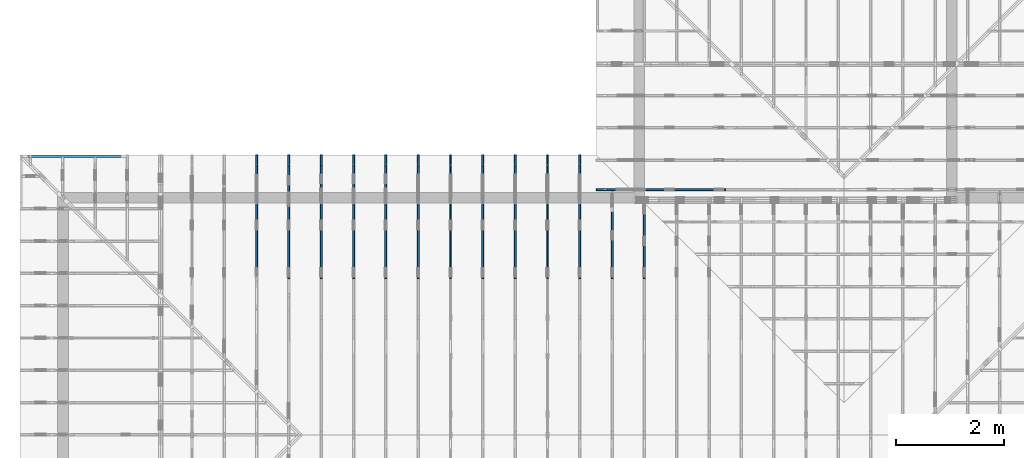
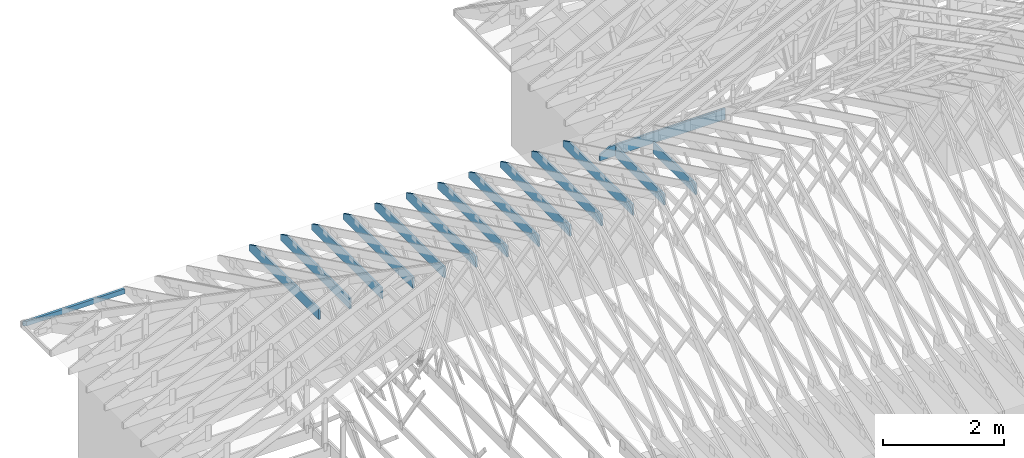
# One storey, part 21 of 159: 15 members, 15 elements without a shape of their own.
"""IFC2X3 building model written with IfcOpenShell, lengths in millimetres."""

from ifc_helpers import new_model, si_unit, frame, origin, origin_with_axes, origin_2d, place, context, project, spatial, faceted_brep, element, aggregate, save


model = new_model("IFC2X3")

# Units and contexts
model_context = context("Model", 3, precision=1e-05, world=origin())
plan_context = context("Plan", 2, precision=1e-05, world=origin_2d())
ifc_project = project(units=[si_unit("LENGTHUNIT", "METRE", prefix="MILLI"), si_unit("AREAUNIT", "SQUARE_METRE"), si_unit("VOLUMEUNIT", "CUBIC_METRE"), si_unit("SOLIDANGLEUNIT", "STERADIAN"), si_unit("PLANEANGLEUNIT", "RADIAN"), si_unit("MASSUNIT", "GRAM"), si_unit("TIMEUNIT", "SECOND"), si_unit("THERMODYNAMICTEMPERATUREUNIT", "DEGREE_CELSIUS"), si_unit("LUMINOUSINTENSITYUNIT", "LUMEN")], contexts=[model_context, plan_context])

# Site, building, storey
site_placement = place(None, origin_with_axes())
site = spatial("IfcSite", under=ifc_project, at=site_placement, CompositionType="ELEMENT")
building_placement = place(site_placement, origin_with_axes())
building = spatial("IfcBuilding", under=site, at=building_placement, Name="Plan 1", CompositionType="ELEMENT")
storey_placement = place(building_placement, origin_with_axes())
storey = spatial("IfcBuildingStorey", under=building, at=storey_placement, Name="Etasje 1", CompositionType="ELEMENT", Elevation=0.0)

# Assembly, member
assembly_1_placement = place(storey_placement, frame((10000.012663278096, 9072.000080051337, 1.1021457184401395e-15), z_axis=(9.811600543477555e-09, 1.0, 6.123031769111886e-17), x_axis=(-1.0, 9.811600543477555e-09, 0.0)))
assembly_1 = element("IfcElementAssembly", 1, at=assembly_1_placement, inside=storey, Name="T9 (79)", AssemblyPlace="FACTORY", PredefinedType="TRUSS")
member_1_placement = place(assembly_1_placement, frame((-2400.0, -2.5443114282097926e-10, -36.0), z_axis=(0.0, 0.0, 1.0), x_axis=(1.0, 1.0601297617540695e-13, 0.0)))
member_1 = element("IfcMember", 2, at=member_1_placement, Name="T9-U13", context=model_context, shape_type="Brep", body=[
    faceted_brep([(2188.818710327172, 223.0000000000224, 36.0), (2.3646862246096134e-11, 223.0000000000224, 36.0), (0.0, 2.5443114282097926e-10, 36.0), (2400.000000000024, 2.5443114282097926e-10, 36.0), (2400.0000000000236, 120.0, 36.0), (2.3646862246096134e-11, 223.00000000025443, 2.8958097754531817e-27), (2188.818710327172, 223.00000000025443, 2.680441300031956e-13), (2400.0000000000236, 120.0, 2.939055249173734e-13), (2400.000000000024, 2.5443114282097926e-10, 2.9390552491737347e-13), (0.0, 2.5443114282097926e-10, 0.0), (2.3646862246096134e-11, 223.00000000025443, 0.0), (2.3646862246096134e-11, 223.00000000025443, 36.0), (2188.818704317352, 223.00000000002245, 36.0), (2188.818704317352, 223.00000000002248, 4.733165431326071e-30), (2.4101609596982585e-11, 2.5443114282097673e-10, 7.174648137343064e-43), (2.4103813888419466e-11, 2.5443114282097673e-10, 36.0), (2.3635963141126885e-11, 223.00000000025443, 36.0), (2.3633758849690005e-11, 223.00000000025443, 8.023251247799073e-31), (2400.000000000024, 3.265278672449041e-13, -1.9993405046408667e-29), (2400.000000000024, 3.2873215868178437e-13, 36.0), (2.4101609596982598e-11, 2.544333471124136e-10, 36.0), (2.4101609596982598e-11, 2.5443114282097673e-10, 0.0), (2400.000000000024, 120.0000000000789, 2.524354896707238e-29), (2400.000000000024, 120.0000000000789, 36.0), (2400.000000000024, 0.0, 36.0), (2400.000000000024, 0.0, 0.0), (2188.8187043173525, 223.0000000000225, 6.860808174957205e-30), (2188.8187043173525, 223.0000000000225, 36.0), (2400.0000000000236, 120.00000000007901, 36.0), (2400.0000000000236, 120.00000000007901, 6.136779558658464e-30)], [[[0, 1, 2, 3, 4]], [[5, 6, 7, 8, 9]], [[10, 11, 12, 13]], [[14, 15, 16, 17]], [[18, 19, 20, 21]], [[22, 23, 24, 25]], [[26, 27, 28, 29]]]),
])
aggregate(assembly_1, [member_1])

assembly_2_placement = place(storey_placement, frame((10875.02226140475, -699.9989301294845, 1.1021457184401395e-15), z_axis=(-1.0, 1.836909530733566e-16, 6.123031769111886e-17), x_axis=(-1.836909530733566e-16, -1.0, 0.0)))
assembly_2 = element("IfcElementAssembly", 3, at=assembly_2_placement, inside=storey, Name="T4 (96)", AssemblyPlace="FACTORY", PredefinedType="TRUSS")
member_2_placement = place(assembly_2_placement, frame((-9501.9990234375, 0.0, -36.0), z_axis=(0.0, 0.0, 1.0), x_axis=(1.0, 0.0, 0.0)))
member_2 = element("IfcMember", 4, at=member_2_placement, Name="T4-U19", context=model_context, shape_type="Brep", body=[
    faceted_brep([(1402.0, 223.0, 36.0), (0.0, 223.0, 36.0), (0.0, 0.0, 36.0), (1402.0, 0.0, 36.0), (0.0, 223.0, 0.0), (1402.0, 223.0, 1.716898108058973e-13), (1402.0, 0.0, 1.716898108058973e-13), (0.0, 0.0, 0.0), (9.331764886155725e-05, 0.0, 0.0), (9.331764886376154e-05, -2.6993892992798474e-31, 36.0), (9.331764889107026e-05, 223.0, 36.0), (9.331764888886597e-05, 223.0, -1.6721217180559947e-30), (1402.0000933176434, -2.5753473335045277e-13, 1.5768933539545808e-29), (1402.0000933176434, -2.553304419135725e-13, 36.0), (9.331764886155725e-05, 2.204274295272421e-15, 36.0), (9.331764886155725e-05, -1.714160785794428e-20, 1.0495860948785078e-36), (1402.0000933176434, 223.0, 0.0), (1402.0000933176434, 223.0, 36.0), (1402.0000933176434, 0.0, 36.0), (1402.0000933176434, 0.0, 0.0), (9.331764886155725e-05, 223.0, 0.0), (9.331764886155725e-05, 223.0, 36.0), (1402.0000933176434, 222.99999999999991, 36.0), (1402.0000933176434, 222.99999999999991, -4.733165431326071e-30)], [[[0, 1, 2, 3]], [[4, 5, 6, 7]], [[8, 9, 10, 11]], [[12, 13, 14, 15]], [[16, 17, 18, 19]], [[20, 21, 22, 23]]]),
])
aggregate(assembly_2, [member_2])

assembly_3_placement = place(storey_placement, frame((10275.02226140475, -699.9989301294845, 1.1021457184401395e-15), z_axis=(-1.0, 1.836909530733566e-16, 6.123031769111886e-17), x_axis=(-1.836909530733566e-16, -1.0, 0.0)))
assembly_3 = element("IfcElementAssembly", 5, at=assembly_3_placement, inside=storey, Name="T3 (95)", AssemblyPlace="FACTORY", PredefinedType="TRUSS")
member_3_placement = place(assembly_3_placement, frame((-8099.998930129477, 223.0, -36.0), z_axis=(0.0, 0.0, 1.0), x_axis=(-1.0, 1.2246063538223773e-16, 0.0)))
member_3 = element("IfcMember", 6, at=member_3_placement, Name="T3-U16", context=model_context, shape_type="Brep", body=[
    faceted_brep([(1600.0000933080228, 223.0000000000002, 36.0), (9.330802276963368e-05, 223.0000000000002, 36.0), (9.330802276963368e-05, 0.0, 36.0), (1600.0000933080228, 0.0, 36.0), (9.330802276963368e-05, 223.0000000000002, 1.1426559754629646e-20), (1600.0000933080228, 223.0000000000002, 1.9593702803814013e-13), (1600.0000933080228, 0.0, 1.9593702803814013e-13), (9.330802276963368e-05, 0.0, 1.1426559754629646e-20), (0.0, 0.0, 0.0), (2.204291436880279e-15, -2.6993892992798474e-31, 36.0), (2.951301312711929e-14, 223.0, 36.0), (2.7308721690239013e-14, 223.0, -1.6721217048316832e-30), (1600.0, -2.9390552491737054e-13, 3.0177820746103793e-29), (1600.0, -2.9170123348049026e-13, 36.0), (4.049083948919771e-31, 2.204291436880279e-15, 36.0), (0.0, 0.0, 0.0), (1600.0, 223.0000000000002, 0.0), (1600.0, 223.0000000000002, 36.0), (1600.0, 1.9895196601282805e-13, 36.0), (1600.0, 1.9895196601282805e-13, 0.0), (0.0, 223.0, 0.0), (0.0, 223.0, 36.0), (1600.0, 223.00000000000026, 36.0), (1600.0, 223.00000000000026, 3.1554436208840472e-30)], [[[0, 1, 2, 3]], [[4, 5, 6, 7]], [[8, 9, 10, 11]], [[12, 13, 14, 15]], [[16, 17, 18, 19]], [[20, 21, 22, 23]]]),
])
aggregate(assembly_3, [member_3])

assembly_4_placement = place(storey_placement, frame((9675.022261404752, 9699.99999999999, 1.1021457184401395e-15), z_axis=(-1.0, 1.836909530733566e-16, 6.123031769111886e-17), x_axis=(-1.836909530733566e-16, -1.0, 0.0)))
assembly_4 = element("IfcElementAssembly", 7, at=assembly_4_placement, inside=storey, Name="T2 (94)", AssemblyPlace="FACTORY", PredefinedType="TRUSS")
member_4_placement = place(assembly_4_placement, frame((2300.0, 223.0, -36.0), z_axis=(0.0, 0.0, 1.0), x_axis=(-1.0, 1.2246063538223773e-16, 0.0)))
member_4 = element("IfcMember", 8, at=member_4_placement, Name="T2-U14", context=model_context, shape_type="Brep", body=[
    faceted_brep([(2300.0, 223.0, 36.0), (0.0, 223.0, 36.0), (0.0, 0.0, 36.0), (2088.8187103271484, 0.0, 36.0), (2300.0, 103.00000000000028, 36.0), (0.0, 223.0, 0.0), (2300.0, 223.0, 2.8165946137914677e-13), (2300.0, 103.00000000000028, 2.8165946137914677e-13), (2088.8187103271484, 2.5579538487363607e-13, 2.5579806646496897e-13), (0.0, 2.5579538487363607e-13, 0.0), (2088.818704317331, -3.836970985935046e-13, 3.91563279237756e-29), (2088.818704317331, -3.814928071566243e-13, 36.0), (1.8189894035458565e-12, 2.204291436879722e-15, 36.0), (1.8189894035458565e-12, -5.568841607314696e-28, 3.4098194078739984e-44), (2299.9999999999995, 103.00000000000091, -3.155443620884047e-29), (2299.9999999999995, 103.00000000000091, 36.0), (2088.8187043173307, 5.684341886080801e-13, 36.0), (2088.8187043173307, 5.684341886080801e-13, -3.155443620884047e-29), (2300.0, 223.00000000000028, 0.0), (2300.0, 223.00000000000028, 36.0), (2300.0, 103.00000000000063, 36.0), (2300.0, 103.00000000000063, 0.0), (1.8189894035458565e-12, 223.0, 0.0), (1.8189894035458565e-12, 223.0, 36.0), (2300.0, 223.00000000000037, 36.0), (2300.0, 223.00000000000037, 4.733165431326071e-30), (1.8189894035458565e-12, 0.0, 0.0), (1.8211936949827368e-12, -2.6993892992798474e-31, 36.0), (1.8485024166729758e-12, 223.0, 36.0), (1.8462981252360955e-12, 223.0, -1.6721217048316832e-30)], [[[0, 1, 2, 3, 4]], [[5, 6, 7, 8, 9]], [[10, 11, 12, 13]], [[14, 15, 16, 17]], [[18, 19, 20, 21]], [[22, 23, 24, 25]], [[26, 27, 28, 29]]]),
])
aggregate(assembly_4, [member_4])

assembly_5_placement = place(storey_placement, frame((9075.022261404752, 9699.99999999999, 1.1021457184401395e-15), z_axis=(-1.0, 1.836909530733566e-16, 6.123031769111886e-17), x_axis=(-1.836909530733566e-16, -1.0, 0.0)))
assembly_5 = element("IfcElementAssembly", 9, at=assembly_5_placement, inside=storey, Name="T2 (93)", AssemblyPlace="FACTORY", PredefinedType="TRUSS")
member_5_placement = place(assembly_5_placement, frame((2300.0, 223.0, -36.0), z_axis=(0.0, 0.0, 1.0), x_axis=(-1.0, 1.2246063538223773e-16, 0.0)))
member_5 = element("IfcMember", 10, at=member_5_placement, Name="T2-U14", context=model_context, shape_type="Brep", body=[
    faceted_brep([(2300.0, 223.0, 36.0), (0.0, 223.0, 36.0), (0.0, 0.0, 36.0), (2088.8187103271484, 0.0, 36.0), (2300.0, 103.00000000000028, 36.0), (0.0, 223.0, 0.0), (2300.0, 223.0, 2.8165946137914677e-13), (2300.0, 103.00000000000028, 2.8165946137914677e-13), (2088.8187103271484, 2.5579538487363607e-13, 2.5579806646496897e-13), (0.0, 2.5579538487363607e-13, 0.0), (2088.818704317331, -3.836970985935046e-13, 3.91563279237756e-29), (2088.818704317331, -3.814928071566243e-13, 36.0), (1.8189894035458565e-12, 2.204291436879722e-15, 36.0), (1.8189894035458565e-12, -5.568841607314696e-28, 3.4098194078739984e-44), (2299.9999999999995, 103.00000000000091, -3.155443620884047e-29), (2299.9999999999995, 103.00000000000091, 36.0), (2088.8187043173307, 5.684341886080801e-13, 36.0), (2088.8187043173307, 5.684341886080801e-13, -3.155443620884047e-29), (2300.0, 223.00000000000028, 0.0), (2300.0, 223.00000000000028, 36.0), (2300.0, 103.00000000000063, 36.0), (2300.0, 103.00000000000063, 0.0), (1.8189894035458565e-12, 223.0, 0.0), (1.8189894035458565e-12, 223.0, 36.0), (2300.0, 223.00000000000037, 36.0), (2300.0, 223.00000000000037, 4.733165431326071e-30), (1.8189894035458565e-12, 0.0, 0.0), (1.8211936949827368e-12, -2.6993892992798474e-31, 36.0), (1.8485024166729758e-12, 223.0, 36.0), (1.8462981252360955e-12, 223.0, -1.6721217048316832e-30)], [[[0, 1, 2, 3, 4]], [[5, 6, 7, 8, 9]], [[10, 11, 12, 13]], [[14, 15, 16, 17]], [[18, 19, 20, 21]], [[22, 23, 24, 25]], [[26, 27, 28, 29]]]),
])
aggregate(assembly_5, [member_5])

assembly_6_placement = place(storey_placement, frame((8475.022261404752, 9699.99999999999, 1.1021457184401395e-15), z_axis=(-1.0, 1.836909530733566e-16, 6.123031769111886e-17), x_axis=(-1.836909530733566e-16, -1.0, 0.0)))
assembly_6 = element("IfcElementAssembly", 11, at=assembly_6_placement, inside=storey, Name="T2 (92)", AssemblyPlace="FACTORY", PredefinedType="TRUSS")
member_6_placement = place(assembly_6_placement, frame((2300.0, 223.0, -36.0), z_axis=(0.0, 0.0, 1.0), x_axis=(-1.0, 1.2246063538223773e-16, 0.0)))
member_6 = element("IfcMember", 12, at=member_6_placement, Name="T2-U14", context=model_context, shape_type="Brep", body=[
    faceted_brep([(2300.0, 223.0, 36.0), (0.0, 223.0, 36.0), (0.0, 0.0, 36.0), (2088.8187103271484, 0.0, 36.0), (2300.0, 103.00000000000028, 36.0), (0.0, 223.0, 0.0), (2300.0, 223.0, 2.8165946137914677e-13), (2300.0, 103.00000000000028, 2.8165946137914677e-13), (2088.8187103271484, 2.5579538487363607e-13, 2.5579806646496897e-13), (0.0, 2.5579538487363607e-13, 0.0), (2088.818704317331, -3.836970985935046e-13, 3.91563279237756e-29), (2088.818704317331, -3.814928071566243e-13, 36.0), (1.8189894035458565e-12, 2.204291436879722e-15, 36.0), (1.8189894035458565e-12, -5.568841607314696e-28, 3.4098194078739984e-44), (2299.9999999999995, 103.00000000000091, -3.155443620884047e-29), (2299.9999999999995, 103.00000000000091, 36.0), (2088.8187043173307, 5.684341886080801e-13, 36.0), (2088.8187043173307, 5.684341886080801e-13, -3.155443620884047e-29), (2300.0, 223.00000000000028, 0.0), (2300.0, 223.00000000000028, 36.0), (2300.0, 103.00000000000063, 36.0), (2300.0, 103.00000000000063, 0.0), (1.8189894035458565e-12, 223.0, 0.0), (1.8189894035458565e-12, 223.0, 36.0), (2300.0, 223.00000000000037, 36.0), (2300.0, 223.00000000000037, 4.733165431326071e-30), (1.8189894035458565e-12, 0.0, 0.0), (1.8211936949827368e-12, -2.6993892992798474e-31, 36.0), (1.8485024166729758e-12, 223.0, 36.0), (1.8462981252360955e-12, 223.0, -1.6721217048316832e-30)], [[[0, 1, 2, 3, 4]], [[5, 6, 7, 8, 9]], [[10, 11, 12, 13]], [[14, 15, 16, 17]], [[18, 19, 20, 21]], [[22, 23, 24, 25]], [[26, 27, 28, 29]]]),
])
aggregate(assembly_6, [member_6])

assembly_7_placement = place(storey_placement, frame((7875.0222614047525, 9699.99999999999, 1.1021457184401395e-15), z_axis=(-1.0, 1.836909530733566e-16, 6.123031769111886e-17), x_axis=(-1.836909530733566e-16, -1.0, 0.0)))
assembly_7 = element("IfcElementAssembly", 13, at=assembly_7_placement, inside=storey, Name="T2 (91)", AssemblyPlace="FACTORY", PredefinedType="TRUSS")
member_7_placement = place(assembly_7_placement, frame((2300.0, 223.0, -36.0), z_axis=(0.0, 0.0, 1.0), x_axis=(-1.0, 1.2246063538223773e-16, 0.0)))
member_7 = element("IfcMember", 14, at=member_7_placement, Name="T2-U14", context=model_context, shape_type="Brep", body=[
    faceted_brep([(2300.0, 223.0, 36.0), (0.0, 223.0, 36.0), (0.0, 0.0, 36.0), (2088.8187103271484, 0.0, 36.0), (2300.0, 103.00000000000028, 36.0), (0.0, 223.0, 0.0), (2300.0, 223.0, 2.8165946137914677e-13), (2300.0, 103.00000000000028, 2.8165946137914677e-13), (2088.8187103271484, 2.5579538487363607e-13, 2.5579806646496897e-13), (0.0, 2.5579538487363607e-13, 0.0), (2088.818704317331, -3.836970985935046e-13, 3.91563279237756e-29), (2088.818704317331, -3.814928071566243e-13, 36.0), (1.8189894035458565e-12, 2.204291436879722e-15, 36.0), (1.8189894035458565e-12, -5.568841607314696e-28, 3.4098194078739984e-44), (2299.9999999999995, 103.00000000000091, -3.155443620884047e-29), (2299.9999999999995, 103.00000000000091, 36.0), (2088.8187043173307, 5.684341886080801e-13, 36.0), (2088.8187043173307, 5.684341886080801e-13, -3.155443620884047e-29), (2300.0, 223.00000000000028, 0.0), (2300.0, 223.00000000000028, 36.0), (2300.0, 103.00000000000063, 36.0), (2300.0, 103.00000000000063, 0.0), (1.8189894035458565e-12, 223.0, 0.0), (1.8189894035458565e-12, 223.0, 36.0), (2300.0, 223.00000000000037, 36.0), (2300.0, 223.00000000000037, 4.733165431326071e-30), (1.8189894035458565e-12, 0.0, 0.0), (1.8211936949827368e-12, -2.6993892992798474e-31, 36.0), (1.8485024166729758e-12, 223.0, 36.0), (1.8462981252360955e-12, 223.0, -1.6721217048316832e-30)], [[[0, 1, 2, 3, 4]], [[5, 6, 7, 8, 9]], [[10, 11, 12, 13]], [[14, 15, 16, 17]], [[18, 19, 20, 21]], [[22, 23, 24, 25]], [[26, 27, 28, 29]]]),
])
aggregate(assembly_7, [member_7])

assembly_8_placement = place(storey_placement, frame((7275.0222614047525, 9699.99999999999, 1.1021457184401395e-15), z_axis=(-1.0, 1.836909530733566e-16, 6.123031769111886e-17), x_axis=(-1.836909530733566e-16, -1.0, 0.0)))
assembly_8 = element("IfcElementAssembly", 15, at=assembly_8_placement, inside=storey, Name="T2 (90)", AssemblyPlace="FACTORY", PredefinedType="TRUSS")
member_8_placement = place(assembly_8_placement, frame((2300.0, 223.0, -36.0), z_axis=(0.0, 0.0, 1.0), x_axis=(-1.0, 1.2246063538223773e-16, 0.0)))
member_8 = element("IfcMember", 16, at=member_8_placement, Name="T2-U14", context=model_context, shape_type="Brep", body=[
    faceted_brep([(2300.0, 223.0, 36.0), (0.0, 223.0, 36.0), (0.0, 0.0, 36.0), (2088.8187103271484, 0.0, 36.0), (2300.0, 103.00000000000028, 36.0), (0.0, 223.0, 0.0), (2300.0, 223.0, 2.8165946137914677e-13), (2300.0, 103.00000000000028, 2.8165946137914677e-13), (2088.8187103271484, 2.5579538487363607e-13, 2.5579806646496897e-13), (0.0, 2.5579538487363607e-13, 0.0), (2088.818704317331, -3.836970985935046e-13, 3.91563279237756e-29), (2088.818704317331, -3.814928071566243e-13, 36.0), (1.8189894035458565e-12, 2.204291436879722e-15, 36.0), (1.8189894035458565e-12, -5.568841607314696e-28, 3.4098194078739984e-44), (2299.9999999999995, 103.00000000000091, -3.155443620884047e-29), (2299.9999999999995, 103.00000000000091, 36.0), (2088.8187043173307, 5.684341886080801e-13, 36.0), (2088.8187043173307, 5.684341886080801e-13, -3.155443620884047e-29), (2300.0, 223.00000000000028, 0.0), (2300.0, 223.00000000000028, 36.0), (2300.0, 103.00000000000063, 36.0), (2300.0, 103.00000000000063, 0.0), (1.8189894035458565e-12, 223.0, 0.0), (1.8189894035458565e-12, 223.0, 36.0), (2300.0, 223.00000000000037, 36.0), (2300.0, 223.00000000000037, 4.733165431326071e-30), (1.8189894035458565e-12, 0.0, 0.0), (1.8211936949827368e-12, -2.6993892992798474e-31, 36.0), (1.8485024166729758e-12, 223.0, 36.0), (1.8462981252360955e-12, 223.0, -1.6721217048316832e-30)], [[[0, 1, 2, 3, 4]], [[5, 6, 7, 8, 9]], [[10, 11, 12, 13]], [[14, 15, 16, 17]], [[18, 19, 20, 21]], [[22, 23, 24, 25]], [[26, 27, 28, 29]]]),
])
aggregate(assembly_8, [member_8])

assembly_9_placement = place(storey_placement, frame((6675.0222614047525, 9699.99999999999, 1.1021457184401395e-15), z_axis=(-1.0, 1.836909530733566e-16, 6.123031769111886e-17), x_axis=(-1.836909530733566e-16, -1.0, 0.0)))
assembly_9 = element("IfcElementAssembly", 17, at=assembly_9_placement, inside=storey, Name="T2 (89)", AssemblyPlace="FACTORY", PredefinedType="TRUSS")
member_9_placement = place(assembly_9_placement, frame((2300.0, 223.0, -36.0), z_axis=(0.0, 0.0, 1.0), x_axis=(-1.0, 1.2246063538223773e-16, 0.0)))
member_9 = element("IfcMember", 18, at=member_9_placement, Name="T2-U14", context=model_context, shape_type="Brep", body=[
    faceted_brep([(2300.0, 223.0, 36.0), (0.0, 223.0, 36.0), (0.0, 0.0, 36.0), (2088.8187103271484, 0.0, 36.0), (2300.0, 103.00000000000028, 36.0), (0.0, 223.0, 0.0), (2300.0, 223.0, 2.8165946137914677e-13), (2300.0, 103.00000000000028, 2.8165946137914677e-13), (2088.8187103271484, 2.5579538487363607e-13, 2.5579806646496897e-13), (0.0, 2.5579538487363607e-13, 0.0), (2088.818704317331, -3.836970985935046e-13, 3.91563279237756e-29), (2088.818704317331, -3.814928071566243e-13, 36.0), (1.8189894035458565e-12, 2.204291436879722e-15, 36.0), (1.8189894035458565e-12, -5.568841607314696e-28, 3.4098194078739984e-44), (2299.9999999999995, 103.00000000000091, -3.155443620884047e-29), (2299.9999999999995, 103.00000000000091, 36.0), (2088.8187043173307, 5.684341886080801e-13, 36.0), (2088.8187043173307, 5.684341886080801e-13, -3.155443620884047e-29), (2300.0, 223.00000000000028, 0.0), (2300.0, 223.00000000000028, 36.0), (2300.0, 103.00000000000063, 36.0), (2300.0, 103.00000000000063, 0.0), (1.8189894035458565e-12, 223.0, 0.0), (1.8189894035458565e-12, 223.0, 36.0), (2300.0, 223.00000000000037, 36.0), (2300.0, 223.00000000000037, 4.733165431326071e-30), (1.8189894035458565e-12, 0.0, 0.0), (1.8211936949827368e-12, -2.6993892992798474e-31, 36.0), (1.8485024166729758e-12, 223.0, 36.0), (1.8462981252360955e-12, 223.0, -1.6721217048316832e-30)], [[[0, 1, 2, 3, 4]], [[5, 6, 7, 8, 9]], [[10, 11, 12, 13]], [[14, 15, 16, 17]], [[18, 19, 20, 21]], [[22, 23, 24, 25]], [[26, 27, 28, 29]]]),
])
aggregate(assembly_9, [member_9])

assembly_10_placement = place(storey_placement, frame((5475.0222614047525, 9699.99999999999, 1.1021457184401395e-15), z_axis=(-1.0, 1.836909530733566e-16, 6.123031769111886e-17), x_axis=(-1.836909530733566e-16, -1.0, 0.0)))
assembly_10 = element("IfcElementAssembly", 19, at=assembly_10_placement, inside=storey, Name="T1 (87)", AssemblyPlace="FACTORY", PredefinedType="TRUSS")
member_10_placement = place(assembly_10_placement, frame((2300.0, 223.0, -36.0), z_axis=(0.0, 0.0, 1.0), x_axis=(-1.0, 1.2246063538223773e-16, 0.0)))
member_10 = element("IfcMember", 20, at=member_10_placement, Name="T1-U14", context=model_context, shape_type="Brep", body=[
    faceted_brep([(2300.0, 223.0, 36.0), (0.0, 223.0, 36.0), (0.0, 0.0, 36.0), (2088.8187103271484, 0.0, 36.0), (2300.0, 103.00000000000028, 36.0), (0.0, 223.0, 0.0), (2300.0, 223.0, 2.8165946137914677e-13), (2300.0, 103.00000000000028, 2.8165946137914677e-13), (2088.8187103271484, 2.5579538487363607e-13, 2.5579806646496897e-13), (0.0, 2.5579538487363607e-13, 0.0), (2088.818704317331, -3.836970985935046e-13, 3.91563279237756e-29), (2088.818704317331, -3.814928071566243e-13, 36.0), (1.8189894035458565e-12, 2.204291436879722e-15, 36.0), (1.8189894035458565e-12, -5.568841607314696e-28, 3.4098194078739984e-44), (2299.9999999999995, 103.00000000000091, -3.155443620884047e-29), (2299.9999999999995, 103.00000000000091, 36.0), (2088.8187043173307, 5.684341886080801e-13, 36.0), (2088.8187043173307, 5.684341886080801e-13, -3.155443620884047e-29), (2300.0, 223.00000000000028, 0.0), (2300.0, 223.00000000000028, 36.0), (2300.0, 103.00000000000063, 36.0), (2300.0, 103.00000000000063, 0.0), (1.8189894035458565e-12, 223.0, 0.0), (1.8189894035458565e-12, 223.0, 36.0), (2300.0, 223.00000000000037, 36.0), (2300.0, 223.00000000000037, 4.733165431326071e-30), (1.8189894035458565e-12, 0.0, 0.0), (1.8211936949827368e-12, -2.6993892992798474e-31, 36.0), (1.8485024166729758e-12, 223.0, 36.0), (1.8462981252360955e-12, 223.0, -1.6721217048316832e-30)], [[[0, 1, 2, 3, 4]], [[5, 6, 7, 8, 9]], [[10, 11, 12, 13]], [[14, 15, 16, 17]], [[18, 19, 20, 21]], [[22, 23, 24, 25]], [[26, 27, 28, 29]]]),
])
aggregate(assembly_10, [member_10])

assembly_11_placement = place(storey_placement, frame((4875.0222614047525, 9699.99999999999, 1.1021457184401395e-15), z_axis=(-1.0, 1.836909530733566e-16, 6.123031769111886e-17), x_axis=(-1.836909530733566e-16, -1.0, 0.0)))
assembly_11 = element("IfcElementAssembly", 21, at=assembly_11_placement, inside=storey, Name="T1 (86)", AssemblyPlace="FACTORY", PredefinedType="TRUSS")
member_11_placement = place(assembly_11_placement, frame((2300.0, 223.0, -36.0), z_axis=(0.0, 0.0, 1.0), x_axis=(-1.0, 1.2246063538223773e-16, 0.0)))
member_11 = element("IfcMember", 22, at=member_11_placement, Name="T1-U14", context=model_context, shape_type="Brep", body=[
    faceted_brep([(2300.0, 223.0, 36.0), (0.0, 223.0, 36.0), (0.0, 0.0, 36.0), (2088.8187103271484, 0.0, 36.0), (2300.0, 103.00000000000028, 36.0), (0.0, 223.0, 0.0), (2300.0, 223.0, 2.8165946137914677e-13), (2300.0, 103.00000000000028, 2.8165946137914677e-13), (2088.8187103271484, 2.5579538487363607e-13, 2.5579806646496897e-13), (0.0, 2.5579538487363607e-13, 0.0), (2088.818704317331, -3.836970985935046e-13, 3.91563279237756e-29), (2088.818704317331, -3.814928071566243e-13, 36.0), (1.8189894035458565e-12, 2.204291436879722e-15, 36.0), (1.8189894035458565e-12, -5.568841607314696e-28, 3.4098194078739984e-44), (2299.9999999999995, 103.00000000000091, -3.155443620884047e-29), (2299.9999999999995, 103.00000000000091, 36.0), (2088.8187043173307, 5.684341886080801e-13, 36.0), (2088.8187043173307, 5.684341886080801e-13, -3.155443620884047e-29), (2300.0, 223.00000000000028, 0.0), (2300.0, 223.00000000000028, 36.0), (2300.0, 103.00000000000063, 36.0), (2300.0, 103.00000000000063, 0.0), (1.8189894035458565e-12, 223.0, 0.0), (1.8189894035458565e-12, 223.0, 36.0), (2300.0, 223.00000000000037, 36.0), (2300.0, 223.00000000000037, 4.733165431326071e-30), (1.8189894035458565e-12, 0.0, 0.0), (1.8211936949827368e-12, -2.6993892992798474e-31, 36.0), (1.8485024166729758e-12, 223.0, 36.0), (1.8462981252360955e-12, 223.0, -1.6721217048316832e-30)], [[[0, 1, 2, 3, 4]], [[5, 6, 7, 8, 9]], [[10, 11, 12, 13]], [[14, 15, 16, 17]], [[18, 19, 20, 21]], [[22, 23, 24, 25]], [[26, 27, 28, 29]]]),
])
aggregate(assembly_11, [member_11])

assembly_12_placement = place(storey_placement, frame((-649.0883117545752, 9651.999999999995, 2.9390552491737054e-15), z_axis=(0.0, -1.0, 6.123031769111886e-17), x_axis=(1.0, 0.0, 0.0)))
assembly_12 = element("IfcElementAssembly", 23, at=assembly_12_placement, inside=storey, Name="uu8 (1)", AssemblyPlace="FACTORY", PredefinedType="TRUSS")
member_12_placement = place(assembly_12_placement, frame((1924.1105957031252, 98.00000038453275, -48.00000008178999), z_axis=(0.0, 0.0, 1.0), x_axis=(-1.0, 1.2246063538223773e-16, 0.0)))
member_12 = element("IfcMember", 24, at=member_12_placement, Name="uu8-U1", context=model_context, shape_type="Brep", body=[
    faceted_brep([(1924.1105935329413, 98.000000384533, 2.2519749336424866e-06), (1876.1105957031255, 98.000000384533, 48.00000008179029), (1876.1105957031255, 3.845329956675414e-07, 48.000000081790404), (1924.1105935329415, 3.845329956675414e-07, 2.251974819955649e-06), (2.2737367544323206e-13, 98.000000384533, 8.178999166830181e-08), (2.2737367544323206e-13, 98.000000384533, 48.00000008178999), (1876.1105957031252, 98.00000038453288, 48.00000008178999), (1924.1105957031252, 98.00000038453288, 8.178999166830181e-08), (2.2543801151186926e-05, 0.0, 0.0), (2.254380115412598e-05, -6.885933811975666e-30, 48.00000008178999), (2.254380138373084e-05, 98.00000187990656, 48.00000092077057), (2.2543801380791785e-05, 98.00000187990656, -1.3661576537347012e-31), (1924.110595703125, 3.8453264222583224e-07, 8.178999166830181e-08), (1876.110595703125, 3.8453265398205323e-07, 48.00000008178999), (5.398778607758988e-31, 3.8453299860659665e-07, 48.00000008178999), (9.199292845733407e-40, 3.845329956675414e-07, 8.178999166830181e-08), (1876.1105957031252, 98.000000384533, 48.00000008178999), (2.2737367544323206e-13, 98.000000384533, 48.00000008178999), (2.2737367544323206e-13, 3.8453276829386596e-07, 48.00000008178999), (1876.1105957031252, 3.8453276829386596e-07, 48.00000008178999), (2.2737367544323203e-13, 98.00000038453275, 8.178999166830181e-08), (1924.1105957031252, 98.00000038453275, 8.17902272961079e-08), (1924.110595703125, 3.845329956675414e-07, 8.17902272961079e-08), (2.2737367544323203e-13, 3.845329956675414e-07, 8.178999166830181e-08)], [[[0, 1, 2, 3]], [[4, 5, 6, 7]], [[8, 9, 10, 11]], [[12, 13, 14, 15]], [[16, 17, 18, 19]], [[20, 21, 22, 23]]]),
])
aggregate(assembly_12, [member_12])

assembly_13_placement = place(storey_placement, frame((3675.02226140475, 9699.999999999993, 1.1021457184401395e-15), z_axis=(-1.0, 1.836909530733566e-16, 6.123031769111886e-17), x_axis=(-1.836909530733566e-16, -1.0, 0.0)))
assembly_13 = element("IfcElementAssembly", 25, at=assembly_13_placement, inside=storey, Name="V4 (5)", AssemblyPlace="FACTORY", PredefinedType="TRUSS")
member_13_placement = place(assembly_13_placement, frame((2300.0, 223.0, -36.0), z_axis=(0.0, 0.0, 1.0), x_axis=(-1.0, 1.2246063538223773e-16, 0.0)))
member_13 = element("IfcMember", 26, at=member_13_placement, Name="V4-U14", context=model_context, shape_type="Brep", body=[
    faceted_brep([(2300.0, 223.0, 36.0), (0.0, 223.0, 36.0), (0.0, 0.0, 36.0), (2088.8187103271484, 0.0, 36.0), (2300.0, 103.00000000000028, 36.0), (0.0, 223.0, 0.0), (2300.0, 223.0, 2.8165946137914677e-13), (2300.0, 103.00000000000028, 2.8165946137914677e-13), (2088.8187103271484, 2.5579538487363607e-13, 2.5579806646496897e-13), (0.0, 2.5579538487363607e-13, 0.0), (2088.818704317331, -3.836970985935046e-13, 3.91563279237756e-29), (2088.818704317331, -3.814928071566243e-13, 36.0), (1.8189894035458565e-12, 2.204291436879722e-15, 36.0), (1.8189894035458565e-12, -5.568841607314696e-28, 3.4098194078739984e-44), (2299.9999999999995, 103.00000000000136, -5.048709793414476e-29), (2299.9999999999995, 103.00000000000136, 36.0), (2088.8187043173307, 9.094947017729282e-13, 36.0), (2088.8187043173307, 9.094947017729282e-13, -5.048709793414476e-29), (2300.0, 223.00000000000028, 0.0), (2300.0, 223.00000000000028, 36.0), (2300.0, 103.00000000000057, 36.0), (2300.0, 103.00000000000057, 0.0), (1.8189894035458565e-12, 223.0, 0.0), (1.8189894035458565e-12, 223.0, 36.0), (2300.0, 223.00000000000037, 36.0), (2300.0, 223.00000000000037, 4.733165431326071e-30), (1.8189894035458565e-12, 0.0, 0.0), (1.8211936949827368e-12, -2.6993892992798474e-31, 36.0), (1.8485024166729758e-12, 223.0, 36.0), (1.8462981252360955e-12, 223.0, -1.6721217048316832e-30)], [[[0, 1, 2, 3, 4]], [[5, 6, 7, 8, 9]], [[10, 11, 12, 13]], [[14, 15, 16, 17]], [[18, 19, 20, 21]], [[22, 23, 24, 25]], [[26, 27, 28, 29]]]),
])
aggregate(assembly_13, [member_13])

assembly_14_placement = place(storey_placement, frame((6075.0222614047525, 9699.99999999999, 1.1021457184401395e-15), z_axis=(-1.0, 1.836909530733566e-16, 6.123031769111886e-17), x_axis=(-1.836909530733566e-16, -1.0, 0.0)))
assembly_14 = element("IfcElementAssembly", 27, at=assembly_14_placement, inside=storey, Name="T1 (88)", AssemblyPlace="FACTORY", PredefinedType="TRUSS")
member_14_placement = place(assembly_14_placement, frame((2300.0, 223.0, -36.0), z_axis=(0.0, 0.0, 1.0), x_axis=(-1.0, 1.2246063538223773e-16, 0.0)))
member_14 = element("IfcMember", 28, at=member_14_placement, Name="T1-U14", context=model_context, shape_type="Brep", body=[
    faceted_brep([(2300.0, 223.0, 36.0), (0.0, 223.0, 36.0), (0.0, 0.0, 36.0), (2088.8187103271484, 0.0, 36.0), (2300.0, 103.00000000000028, 36.0), (0.0, 223.0, 0.0), (2300.0, 223.0, 2.8165946137914677e-13), (2300.0, 103.00000000000028, 2.8165946137914677e-13), (2088.8187103271484, 2.5579538487363607e-13, 2.5579806646496897e-13), (0.0, 2.5579538487363607e-13, 0.0), (2088.818704317331, -3.836970985935046e-13, 3.91563279237756e-29), (2088.818704317331, -3.814928071566243e-13, 36.0), (1.8189894035458565e-12, 2.204291436879722e-15, 36.0), (1.8189894035458565e-12, -5.568841607314696e-28, 3.4098194078739984e-44), (2299.9999999999995, 103.00000000000091, -3.155443620884047e-29), (2299.9999999999995, 103.00000000000091, 36.0), (2088.8187043173307, 5.684341886080801e-13, 36.0), (2088.8187043173307, 5.684341886080801e-13, -3.155443620884047e-29), (2300.0, 223.00000000000028, 0.0), (2300.0, 223.00000000000028, 36.0), (2300.0, 103.00000000000063, 36.0), (2300.0, 103.00000000000063, 0.0), (1.8189894035458565e-12, 223.0, 0.0), (1.8189894035458565e-12, 223.0, 36.0), (2300.0, 223.00000000000037, 36.0), (2300.0, 223.00000000000037, 4.733165431326071e-30), (1.8189894035458565e-12, 0.0, 0.0), (1.8211936949827368e-12, -2.6993892992798474e-31, 36.0), (1.8485024166729758e-12, 223.0, 36.0), (1.8462981252360955e-12, 223.0, -1.6721217048316832e-30)], [[[0, 1, 2, 3, 4]], [[5, 6, 7, 8, 9]], [[10, 11, 12, 13]], [[14, 15, 16, 17]], [[18, 19, 20, 21]], [[22, 23, 24, 25]], [[26, 27, 28, 29]]]),
])
aggregate(assembly_14, [member_14])

assembly_15_placement = place(storey_placement, frame((4275.022261406632, 9700.000260373617, 1.1021457184401395e-15), z_axis=(-0.999999999895379, 1.4465201327097478e-05, 6.123031769111886e-17), x_axis=(-1.4465201327097478e-05, -0.999999999895379, 0.0)))
assembly_15 = element("IfcElementAssembly", 29, at=assembly_15_placement, inside=storey, Name="V13 (6)", AssemblyPlace="FACTORY", PredefinedType="TRUSS")
member_15_placement = place(assembly_15_placement, frame((2300.0, 223.0, -36.0), z_axis=(0.0, 0.0, 1.0), x_axis=(-1.0, 1.2246063538223773e-16, 0.0)))
member_15 = element("IfcMember", 30, at=member_15_placement, Name="V13-U14", context=model_context, shape_type="Brep", body=[
    faceted_brep([(2300.0, 223.0, 36.0), (0.0, 223.0, 36.0), (0.0, 0.0, 36.0), (2088.8187103271484, 0.0, 36.0), (2300.0, 103.00000000000028, 36.0), (0.0, 223.0, 0.0), (2300.0, 223.0, 2.8165946137914677e-13), (2300.0, 103.00000000000028, 2.8165946137914677e-13), (2088.8187103271484, 2.5579538487363607e-13, 2.5579806646496897e-13), (0.0, 2.5579538487363607e-13, 0.0), (2088.818704317331, -3.836970985935046e-13, 3.91563279237756e-29), (2088.818704317331, -3.814928071566243e-13, 36.0), (1.8189894035458565e-12, 2.204291436879722e-15, 36.0), (1.8189894035458565e-12, -5.568841607314696e-28, 3.4098194078739984e-44), (2300.0000000000005, 102.99999999999966, 4.3977829016254926e-29), (2300.0000000000005, 102.99999999999966, 36.0), (2088.8187043173316, -4.547473508864641e-13, 36.0), (2088.8187043173316, -4.547473508864641e-13, 3.839097039078564e-29), (2300.0, 223.00000000000028, 0.0), (2300.0, 223.00000000000028, 36.0), (2300.0, 103.00000000000051, 36.0), (2300.0, 103.00000000000051, 0.0), (1.8189894035458565e-12, 223.0, 0.0), (1.8189894035458565e-12, 223.0, 36.0), (2300.0, 223.00000000000037, 36.0), (2300.0, 223.00000000000037, 4.733165431326071e-30), (1.8189894035458565e-12, 0.0, 0.0), (1.8211936949827368e-12, -2.6993892992798474e-31, 36.0), (1.8485024166729758e-12, 223.0, 36.0), (1.8462981252360955e-12, 223.0, -1.6721217048316832e-30)], [[[0, 1, 2, 3, 4]], [[5, 6, 7, 8, 9]], [[10, 11, 12, 13]], [[14, 15, 16, 17]], [[18, 19, 20, 21]], [[22, 23, 24, 25]], [[26, 27, 28, 29]]]),
])
aggregate(assembly_15, [member_15])

save(model, "model.ifc")
